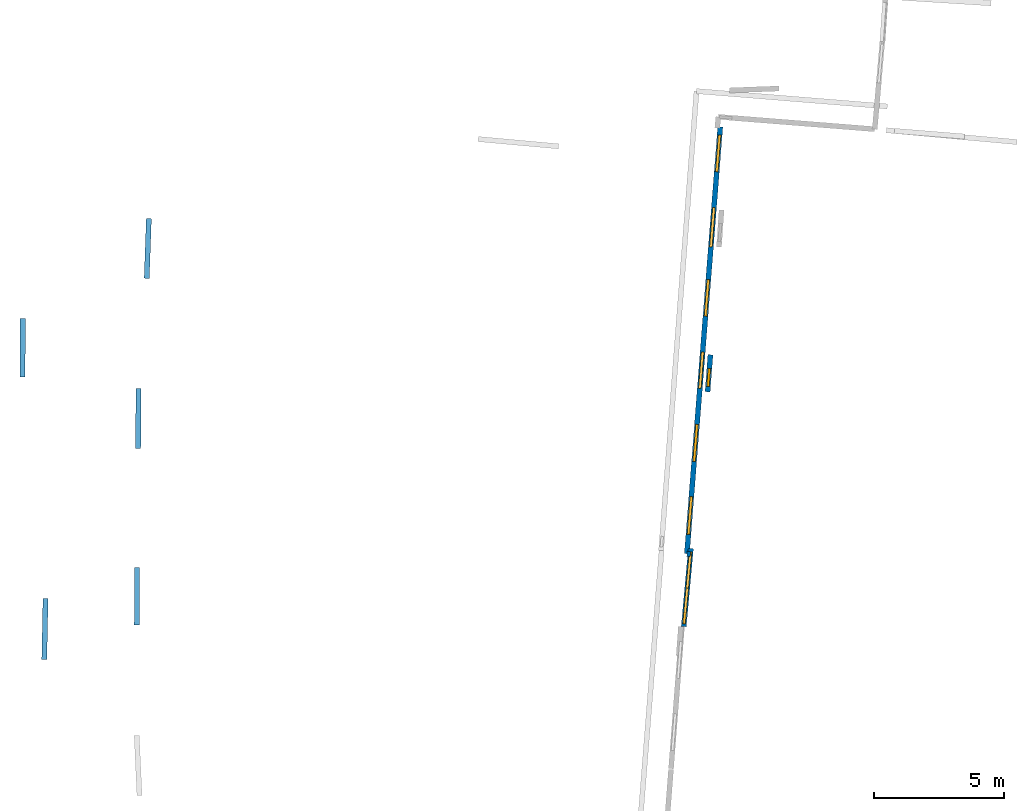
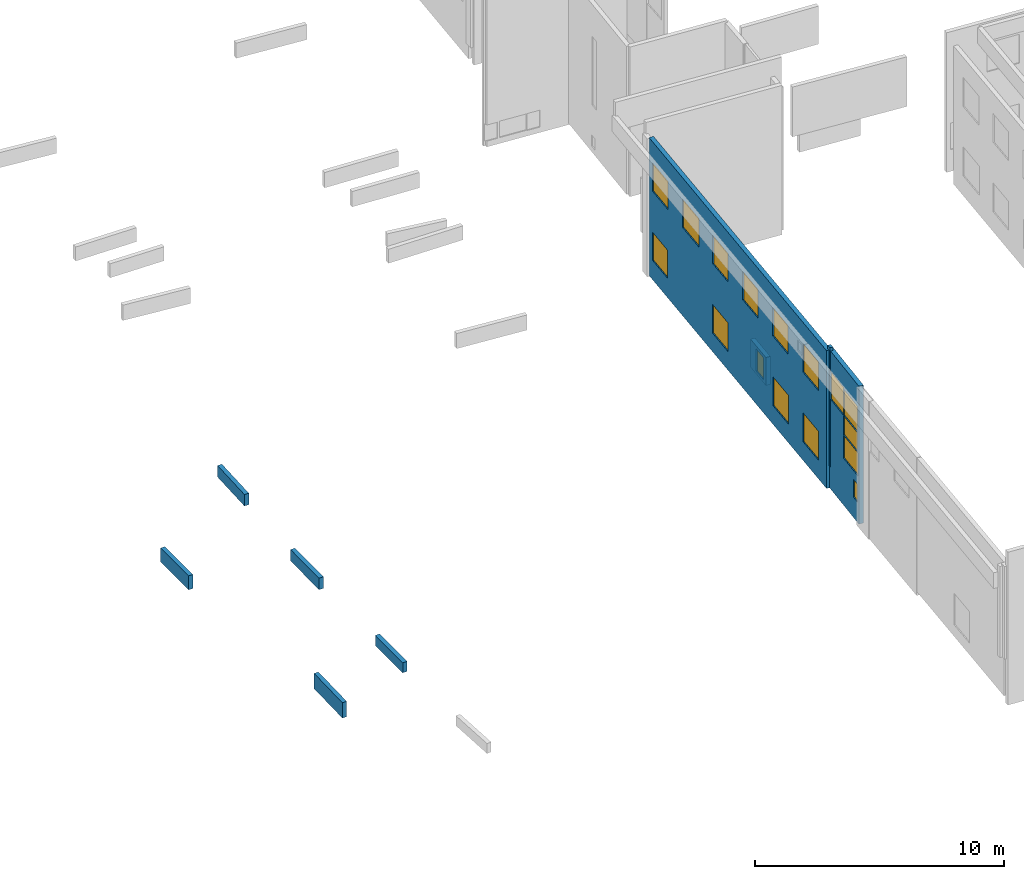
# One storey, part 5 of 27: 16 windows, 9 walls, 16 openings.
"""IFC2X3 building model written with IfcOpenShell, lengths in metres."""

from ifc_helpers import new_model, entity, si_unit, converted_unit, derived_unit, direction, frame, frame_2d, origin, origin_2d_with_axis, place, context, subcontext, project, spatial, polyline, rectangle, outline, extrude, source, transform, mapped, material, layer, layer_set, layer_usage, type_object, type_shapes, element, fill, save


model = new_model("IFC2X3")

# Units and contexts
model_context = context("Model", 3, precision=1e-05, world=origin(), true_north=direction((0.0, 1.0)))
body_context = subcontext(model_context, "Body", "Model", "MODEL_VIEW")
ifc_project = project(units=[si_unit("LENGTHUNIT", "METRE"), si_unit("AREAUNIT", "SQUARE_METRE"), si_unit("VOLUMEUNIT", "CUBIC_METRE"), converted_unit("PLANEANGLEUNIT", "DEGREE", entity("IfcRatioMeasure", 0.0174532925199433), si_unit("PLANEANGLEUNIT", "RADIAN"), dimensions=[0, 0, 0, 0, 0, 0, 0]), si_unit("MASSUNIT", "GRAM", prefix="KILO"), derived_unit("MASSDENSITYUNIT", [(si_unit("MASSUNIT", "GRAM", prefix="KILO"), 1), (si_unit("LENGTHUNIT", "METRE"), -3)]), derived_unit("MOMENTOFINERTIAUNIT", [(si_unit("LENGTHUNIT", "METRE"), 4)]), si_unit("TIMEUNIT", "SECOND"), si_unit("FREQUENCYUNIT", "HERTZ"), si_unit("THERMODYNAMICTEMPERATUREUNIT", "DEGREE_CELSIUS"), derived_unit("THERMALTRANSMITTANCEUNIT", [(si_unit("MASSUNIT", "GRAM", prefix="KILO"), 1), (si_unit("THERMODYNAMICTEMPERATUREUNIT", "KELVIN"), -1), (si_unit("TIMEUNIT", "SECOND"), -3)]), derived_unit("VOLUMETRICFLOWRATEUNIT", [(si_unit("LENGTHUNIT", "METRE"), 3), (si_unit("TIMEUNIT", "SECOND"), -1)]), si_unit("ELECTRICCURRENTUNIT", "AMPERE"), si_unit("ELECTRICVOLTAGEUNIT", "VOLT"), si_unit("POWERUNIT", "WATT"), si_unit("FORCEUNIT", "NEWTON", prefix="KILO"), si_unit("ILLUMINANCEUNIT", "LUX"), si_unit("LUMINOUSFLUXUNIT", "LUMEN"), si_unit("LUMINOUSINTENSITYUNIT", "CANDELA"), derived_unit("USERDEFINED", [(si_unit("MASSUNIT", "GRAM", prefix="KILO"), -1), (si_unit("LENGTHUNIT", "METRE"), -2), (si_unit("TIMEUNIT", "SECOND"), 3), (si_unit("LUMINOUSFLUXUNIT", "LUMEN"), 1)]), derived_unit("LINEARVELOCITYUNIT", [(si_unit("LENGTHUNIT", "METRE"), 1), (si_unit("TIMEUNIT", "SECOND"), -1)]), si_unit("PRESSUREUNIT", "PASCAL"), derived_unit("USERDEFINED", [(si_unit("LENGTHUNIT", "METRE"), -2), (si_unit("MASSUNIT", "GRAM", prefix="KILO"), 1), (si_unit("TIMEUNIT", "SECOND"), -2)]), derived_unit("LINEARFORCEUNIT", [(si_unit("MASSUNIT", "GRAM", prefix="KILO"), 1), (si_unit("LENGTHUNIT", "METRE"), 1), (si_unit("TIMEUNIT", "SECOND"), -2), (si_unit("LENGTHUNIT", "METRE"), -1)]), derived_unit("PLANARFORCEUNIT", [(si_unit("MASSUNIT", "GRAM", prefix="KILO"), 1), (si_unit("LENGTHUNIT", "METRE"), 1), (si_unit("TIMEUNIT", "SECOND"), -2), (si_unit("LENGTHUNIT", "METRE"), -2)])], contexts=[model_context])

# Site, building, storey
placement_1 = place(None, origin())
site = spatial("IfcSite", under=ifc_project, at=placement_1, CompositionType="ELEMENT")
building = spatial("IfcBuilding", under=site, at=placement_1, CompositionType="ELEMENT")
storey_placement = place(placement_1, frame((0.0, 0.0, -61.043098449707)))
storey = spatial("IfcBuildingStorey", under=building, at=storey_placement, Name="level_-61.043098", CompositionType="ELEMENT", Elevation=-61.043098449707)

# Wall, openings, windows
ifc_material_1 = material(Name="Default wall")
ifc_layer = layer(ifc_material_1, 0.2)
ifc_layer_set = layer_set([ifc_layer], Name="wall_thickness_0.2000")
ifc_layer_usage = layer_usage(ifc_layer_set, "AXIS2", "POSITIVE", -0.1)
wall_type = type_object("IfcWallType", Name="wall_thickness_0.2000", PredefinedType="STANDARD", material=ifc_layer_set)
placement_2 = place(placement_1, frame((0.0, 0.0, -60.9578857421875)))
wall_1_placement = place(placement_2, frame((-85.5225113799916, -13.7391285673502, 0.0), z_axis=(0.0, 0.0, 1.0), x_axis=(-0.0778817351425744, -0.996962604780732, 0.0)))
wall_1 = element("IfcWallStandardCase", 1, at=wall_1_placement, inside=storey, type_object=wall_type, material=ifc_layer_usage, Name="Wall:303", ObjectType="Wall", context=body_context, shape_type="SweptSolid", body=[
    extrude(outline(polyline([(16.513137194355, -0.1), (16.513137194355, 0.1), (0.0, 0.1), (0.0, -0.1), (16.513137194355, -0.1)])), origin(), (0.0, 0.0, 1.0), 6.74871063232422),
])
opening_1_placement = place(wall_1_placement, frame((0.320000121720632, -0.1, 4.32806777954102)))
opening_1 = element("IfcOpeningElement", 2, at=opening_1_placement, cuts=wall_1, Name="Opening : 1420 x 1390 : 23", ObjectType="Opening", context=body_context, shape_type="SweptSolid", body=[
    extrude(rectangle(XDim=1.42, YDim=1.39, at=frame_2d((0.695, 0.71), x_axis=(0.0, 1.0))), frame((0.0, 0.0, 0.0), z_axis=(0.0, 1.0, 0.0), x_axis=(0.0, 0.0, 1.0)), (0.0, 0.0, 1.0), 0.2),
])
opening_2_placement = place(wall_1_placement, frame((14.2999979344314, -0.1, 4.31306838989258)))
opening_2 = element("IfcOpeningElement", 3, at=opening_2_placement, cuts=wall_1, Name="Opening : 1450 x 1410 : 24", ObjectType="Opening", context=body_context, shape_type="SweptSolid", body=[
    extrude(rectangle(XDim=1.45, YDim=1.41, at=frame_2d((0.705, 0.725), x_axis=(0.0, 1.0))), frame((0.0, 0.0, 0.0), z_axis=(0.0, 1.0, 0.0), x_axis=(0.0, 0.0, 1.0)), (0.0, 0.0, 1.0), 0.2),
])
opening_3_placement = place(wall_1_placement, frame((3.12000031696189, -0.1, 4.31806564331055)))
opening_3 = element("IfcOpeningElement", 4, at=opening_3_placement, cuts=wall_1, Name="Opening : 1535 x 1395 : 25", ObjectType="Opening", context=body_context, shape_type="SweptSolid", body=[
    extrude(rectangle(XDim=1.535, YDim=1.395, at=frame_2d((0.6975, 0.7675), x_axis=(0.0, 1.0))), frame((0.0, 0.0, 0.0), z_axis=(0.0, 1.0, 0.0), x_axis=(0.0, 0.0, 1.0)), (0.0, 0.0, 1.0), 0.2),
])
opening_4_placement = place(wall_1_placement, frame((5.91499989962284, -0.1, 4.31806564331055)))
opening_4 = element("IfcOpeningElement", 5, at=opening_4_placement, cuts=wall_1, Name="Opening : 1410 x 1395 : 26", ObjectType="Opening", context=body_context, shape_type="SweptSolid", body=[
    extrude(rectangle(XDim=1.41, YDim=1.395, at=frame_2d((0.6975, 0.705), x_axis=(0.0, 1.0))), frame((0.0, 0.0, 0.0), z_axis=(0.0, 1.0, 0.0), x_axis=(0.0, 0.0, 1.0)), (0.0, 0.0, 1.0), 0.2),
])
opening_5_placement = place(wall_1_placement, frame((8.71500104564173, -0.1, 4.31306838989258)))
opening_5 = element("IfcOpeningElement", 6, at=opening_5_placement, cuts=wall_1, Name="Opening : 1400 x 1395 : 27", ObjectType="Opening", context=body_context, shape_type="SweptSolid", body=[
    extrude(rectangle(XDim=1.4, YDim=1.395, at=frame_2d((0.6975, 0.7), x_axis=(0.0, 1.0))), frame((0.0, 0.0, 0.0), z_axis=(0.0, 1.0, 0.0), x_axis=(0.0, 0.0, 1.0)), (0.0, 0.0, 1.0), 0.2),
])
opening_6_placement = place(wall_1_placement, frame((11.5050002533257, -0.1, 4.31306838989258)))
opening_6 = element("IfcOpeningElement", 7, at=opening_6_placement, cuts=wall_1, Name="Opening : 1440 x 1400 : 28", ObjectType="Opening", context=body_context, shape_type="SweptSolid", body=[
    extrude(rectangle(XDim=1.44, YDim=1.4, at=frame_2d((0.7, 0.72), x_axis=(0.0, 1.0))), frame((0.0, 0.0, 0.0), z_axis=(0.0, 1.0, 0.0), x_axis=(0.0, 0.0, 1.0)), (0.0, 0.0, 1.0), 0.2),
])
opening_7_placement = place(wall_1_placement, frame((0.315000103330809, -0.1, 0.943065643310547)))
opening_7 = element("IfcOpeningElement", 8, at=opening_7_placement, cuts=wall_1, Name="Opening : 1420 x 1375 : 29", ObjectType="Opening", context=body_context, shape_type="SweptSolid", body=[
    extrude(rectangle(XDim=1.42, YDim=1.375, at=frame_2d((0.6875, 0.71), x_axis=(0.0, 1.0))), frame((0.0, 0.0, 0.0), z_axis=(0.0, 1.0, 0.0), x_axis=(0.0, 0.0, 1.0)), (0.0, 0.0, 1.0), 0.2),
])
opening_8_placement = place(wall_1_placement, frame((11.5150002901054, -0.1, 0.908065795898438)))
opening_8 = element("IfcOpeningElement", 9, at=opening_8_placement, cuts=wall_1, Name="Opening : 1435 x 1410 : 30", ObjectType="Opening", context=body_context, shape_type="SweptSolid", body=[
    extrude(rectangle(XDim=1.435, YDim=1.41, at=frame_2d((0.705, 0.7175), x_axis=(0.0, 1.0))), frame((0.0, 0.0, 0.0), z_axis=(0.0, 1.0, 0.0), x_axis=(0.0, 0.0, 1.0)), (0.0, 0.0, 1.0), 0.2),
])
opening_9_placement = place(wall_1_placement, frame((14.3099998727663, -0.1, 0.908065795898438)))
opening_9 = element("IfcOpeningElement", 10, at=opening_9_placement, cuts=wall_1, Name="Opening : 1455 x 1415 : 31", ObjectType="Opening", context=body_context, shape_type="SweptSolid", body=[
    extrude(rectangle(XDim=1.455, YDim=1.415, at=frame_2d((0.7075, 0.7275), x_axis=(0.0, 1.0))), frame((0.0, 0.0, 0.0), z_axis=(0.0, 1.0, 0.0), x_axis=(0.0, 0.0, 1.0)), (0.0, 0.0, 1.0), 0.2),
])
opening_10_placement = place(wall_1_placement, frame((5.91000083201065, -0.1, 0.908065795898438)))
opening_10 = element("IfcOpeningElement", 11, at=opening_10_placement, cuts=wall_1, Name="Opening : 1415 x 1405 : 32", ObjectType="Opening", context=body_context, shape_type="SweptSolid", body=[
    extrude(rectangle(XDim=1.415, YDim=1.405, at=frame_2d((0.7025, 0.7075), x_axis=(0.0, 1.0))), frame((0.0, 0.0, 0.0), z_axis=(0.0, 1.0, 0.0), x_axis=(0.0, 0.0, 1.0)), (0.0, 0.0, 1.0), 0.2),
])
ifc_material_2 = material(Name="Window Default")
window_style_1 = type_object("IfcWindowStyle", Name="Window : 1420 x 1390mm", ConstructionType="NOTDEFINED", OperationType="NOTDEFINED", ParameterTakesPrecedence=False, Sizeable=False, material=ifc_material_2)
shared_shape_1 = source(origin(), body_context, "Body", "SweptSolid", [
    extrude(rectangle(XDim=0.1, YDim=1.42, at=origin_2d_with_axis()), frame((0.71, 0.1, 0.0), z_axis=(0.0, 0.0, 1.0), x_axis=(0.0, 1.0, 0.0)), (0.0, 0.0, 1.0), 1.39),
])
type_shapes(window_style_1, [shared_shape_1])
window_1_placement = place(opening_1_placement, origin())
window_1 = element("IfcWindow", 12, at=window_1_placement, inside=storey, type_object=window_style_1, Name="Window : 1420 x 1390mm : 20", ObjectType="Window : 1420 x 1390mm", OverallHeight=1.39, OverallWidth=1.42, context=body_context, shape_type="MappedRepresentation", body=[
    mapped(shared_shape_1, transform((0.0, 0.0, 0.0), scale=1.0)),
])
fill(opening_1, window_1)
window_style_2 = type_object("IfcWindowStyle", Name="Window : 1415 x 1405mm", ConstructionType="NOTDEFINED", OperationType="NOTDEFINED", ParameterTakesPrecedence=False, Sizeable=False, material=ifc_material_2)
shared_shape_2 = source(origin(), body_context, "Body", "SweptSolid", [
    extrude(rectangle(XDim=0.1, YDim=1.415, at=origin_2d_with_axis()), frame((0.7075, 0.1, 0.0), z_axis=(0.0, 0.0, 1.0), x_axis=(0.0, 1.0, 0.0)), (0.0, 0.0, 1.0), 1.405),
])
type_shapes(window_style_2, [shared_shape_2])
window_2_placement = place(opening_10_placement, origin())
window_2 = element("IfcWindow", 13, at=window_2_placement, inside=storey, type_object=window_style_2, Name="Window : 1415 x 1405mm : 29", ObjectType="Window : 1415 x 1405mm", OverallHeight=1.405, OverallWidth=1.415, context=body_context, shape_type="MappedRepresentation", body=[
    mapped(shared_shape_2, transform((0.0, 0.0, 0.0), scale=1.0)),
])
fill(opening_10, window_2)
window_style_3 = type_object("IfcWindowStyle", Name="Window : 1450 x 1410mm", ConstructionType="NOTDEFINED", OperationType="NOTDEFINED", ParameterTakesPrecedence=False, Sizeable=False, material=ifc_material_2)
shared_shape_3 = source(origin(), body_context, "Body", "SweptSolid", [
    extrude(rectangle(XDim=0.1, YDim=1.45, at=origin_2d_with_axis()), frame((0.725, 0.1, 0.0), z_axis=(0.0, 0.0, 1.0), x_axis=(0.0, 1.0, 0.0)), (0.0, 0.0, 1.0), 1.41),
])
type_shapes(window_style_3, [shared_shape_3])
window_3_placement = place(opening_2_placement, origin())
window_3 = element("IfcWindow", 14, at=window_3_placement, inside=storey, type_object=window_style_3, Name="Window : 1450 x 1410mm : 21", ObjectType="Window : 1450 x 1410mm", OverallHeight=1.41, OverallWidth=1.45, context=body_context, shape_type="MappedRepresentation", body=[
    mapped(shared_shape_3, transform((0.0, 0.0, 0.0), scale=1.0)),
])
fill(opening_2, window_3)
window_style_4 = type_object("IfcWindowStyle", Name="Window : 1535 x 1395mm", ConstructionType="NOTDEFINED", OperationType="NOTDEFINED", ParameterTakesPrecedence=False, Sizeable=False, material=ifc_material_2)
shared_shape_4 = source(origin(), body_context, "Body", "SweptSolid", [
    extrude(rectangle(XDim=0.1, YDim=1.535, at=origin_2d_with_axis()), frame((0.7675, 0.1, 0.0), z_axis=(0.0, 0.0, 1.0), x_axis=(0.0, 1.0, 0.0)), (0.0, 0.0, 1.0), 1.395),
])
type_shapes(window_style_4, [shared_shape_4])
window_4_placement = place(opening_3_placement, origin())
window_4 = element("IfcWindow", 15, at=window_4_placement, inside=storey, type_object=window_style_4, Name="Window : 1535 x 1395mm : 22", ObjectType="Window : 1535 x 1395mm", OverallHeight=1.395, OverallWidth=1.535, context=body_context, shape_type="MappedRepresentation", body=[
    mapped(shared_shape_4, transform((0.0, 0.0, 0.0), scale=1.0)),
])
fill(opening_3, window_4)
window_style_5 = type_object("IfcWindowStyle", Name="Window : 1410 x 1395mm", ConstructionType="NOTDEFINED", OperationType="NOTDEFINED", ParameterTakesPrecedence=False, Sizeable=False, material=ifc_material_2)
shared_shape_5 = source(origin(), body_context, "Body", "SweptSolid", [
    extrude(rectangle(XDim=0.1, YDim=1.41, at=origin_2d_with_axis()), frame((0.705, 0.1, 0.0), z_axis=(0.0, 0.0, 1.0), x_axis=(0.0, 1.0, 0.0)), (0.0, 0.0, 1.0), 1.395),
])
type_shapes(window_style_5, [shared_shape_5])
window_5_placement = place(opening_4_placement, origin())
window_5 = element("IfcWindow", 16, at=window_5_placement, inside=storey, type_object=window_style_5, Name="Window : 1410 x 1395mm : 23", ObjectType="Window : 1410 x 1395mm", OverallHeight=1.395, OverallWidth=1.41, context=body_context, shape_type="MappedRepresentation", body=[
    mapped(shared_shape_5, transform((0.0, 0.0, 0.0), scale=1.0)),
])
fill(opening_4, window_5)
window_style_6 = type_object("IfcWindowStyle", Name="Window : 1400 x 1395mm", ConstructionType="NOTDEFINED", OperationType="NOTDEFINED", ParameterTakesPrecedence=False, Sizeable=False, material=ifc_material_2)
shared_shape_6 = source(origin(), body_context, "Body", "SweptSolid", [
    extrude(rectangle(XDim=0.1, YDim=1.4, at=origin_2d_with_axis()), frame((0.7, 0.1, 0.0), z_axis=(0.0, 0.0, 1.0), x_axis=(0.0, 1.0, 0.0)), (0.0, 0.0, 1.0), 1.395),
])
type_shapes(window_style_6, [shared_shape_6])
window_6_placement = place(opening_5_placement, origin())
window_6 = element("IfcWindow", 17, at=window_6_placement, inside=storey, type_object=window_style_6, Name="Window : 1400 x 1395mm : 24", ObjectType="Window : 1400 x 1395mm", OverallHeight=1.395, OverallWidth=1.4, context=body_context, shape_type="MappedRepresentation", body=[
    mapped(shared_shape_6, transform((0.0, 0.0, 0.0), scale=1.0)),
])
fill(opening_5, window_6)
window_style_7 = type_object("IfcWindowStyle", Name="Window : 1440 x 1400mm", ConstructionType="NOTDEFINED", OperationType="NOTDEFINED", ParameterTakesPrecedence=False, Sizeable=False, material=ifc_material_2)
shared_shape_7 = source(origin(), body_context, "Body", "SweptSolid", [
    extrude(rectangle(XDim=0.1, YDim=1.44, at=origin_2d_with_axis()), frame((0.72, 0.1, 0.0), z_axis=(0.0, 0.0, 1.0), x_axis=(0.0, 1.0, 0.0)), (0.0, 0.0, 1.0), 1.4),
])
type_shapes(window_style_7, [shared_shape_7])
window_7_placement = place(opening_6_placement, origin())
window_7 = element("IfcWindow", 18, at=window_7_placement, inside=storey, type_object=window_style_7, Name="Window : 1440 x 1400mm : 25", ObjectType="Window : 1440 x 1400mm", OverallHeight=1.4, OverallWidth=1.44, context=body_context, shape_type="MappedRepresentation", body=[
    mapped(shared_shape_7, transform((0.0, 0.0, 0.0), scale=1.0)),
])
fill(opening_6, window_7)
window_style_8 = type_object("IfcWindowStyle", Name="Window : 1420 x 1375mm", ConstructionType="NOTDEFINED", OperationType="NOTDEFINED", ParameterTakesPrecedence=False, Sizeable=False, material=ifc_material_2)
shared_shape_8 = source(origin(), body_context, "Body", "SweptSolid", [
    extrude(rectangle(XDim=0.1, YDim=1.42, at=origin_2d_with_axis()), frame((0.71, 0.1, 0.0), z_axis=(0.0, 0.0, 1.0), x_axis=(0.0, 1.0, 0.0)), (0.0, 0.0, 1.0), 1.375),
])
type_shapes(window_style_8, [shared_shape_8])
window_8_placement = place(opening_7_placement, origin())
window_8 = element("IfcWindow", 19, at=window_8_placement, inside=storey, type_object=window_style_8, Name="Window : 1420 x 1375mm : 26", ObjectType="Window : 1420 x 1375mm", OverallHeight=1.375, OverallWidth=1.42, context=body_context, shape_type="MappedRepresentation", body=[
    mapped(shared_shape_8, transform((0.0, 0.0, 0.0), scale=1.0)),
])
fill(opening_7, window_8)
window_style_9 = type_object("IfcWindowStyle", Name="Window : 1435 x 1410mm", ConstructionType="NOTDEFINED", OperationType="NOTDEFINED", ParameterTakesPrecedence=False, Sizeable=False, material=ifc_material_2)
shared_shape_9 = source(origin(), body_context, "Body", "SweptSolid", [
    extrude(rectangle(XDim=0.1, YDim=1.435, at=origin_2d_with_axis()), frame((0.7175, 0.1, 0.0), z_axis=(0.0, 0.0, 1.0), x_axis=(0.0, 1.0, 0.0)), (0.0, 0.0, 1.0), 1.41),
])
type_shapes(window_style_9, [shared_shape_9])
window_9_placement = place(opening_8_placement, origin())
window_9 = element("IfcWindow", 20, at=window_9_placement, inside=storey, type_object=window_style_9, Name="Window : 1435 x 1410mm : 27", ObjectType="Window : 1435 x 1410mm", OverallHeight=1.41, OverallWidth=1.435, context=body_context, shape_type="MappedRepresentation", body=[
    mapped(shared_shape_9, transform((0.0, 0.0, 0.0), scale=1.0)),
])
fill(opening_8, window_9)
window_style_10 = type_object("IfcWindowStyle", Name="Window : 1455 x 1415mm", ConstructionType="NOTDEFINED", OperationType="NOTDEFINED", ParameterTakesPrecedence=False, Sizeable=False, material=ifc_material_2)
shared_shape_10 = source(origin(), body_context, "Body", "SweptSolid", [
    extrude(rectangle(XDim=0.1, YDim=1.455, at=origin_2d_with_axis()), frame((0.7275, 0.1, 0.0), z_axis=(0.0, 0.0, 1.0), x_axis=(0.0, 1.0, 0.0)), (0.0, 0.0, 1.0), 1.415),
])
type_shapes(window_style_10, [shared_shape_10])
window_10_placement = place(opening_9_placement, origin())
window_10 = element("IfcWindow", 21, at=window_10_placement, inside=storey, type_object=window_style_10, Name="Window : 1455 x 1415mm : 28", ObjectType="Window : 1455 x 1415mm", OverallHeight=1.415, OverallWidth=1.455, context=body_context, shape_type="MappedRepresentation", body=[
    mapped(shared_shape_10, transform((0.0, 0.0, 0.0), scale=1.0)),
])
fill(opening_9, window_10)

placement_3 = place(placement_1, frame((0.0, 0.0, -60.9578857421875)))
wall_2_placement = place(placement_3, frame((-86.6557621445655, -29.9994877663841, 0.0), z_axis=(0.0, 0.0, 1.0), x_axis=(-0.090893404097552, -0.995860627342782, 0.0)))
wall_2 = element("IfcWallStandardCase", 22, at=wall_2_placement, inside=storey, type_object=wall_type, material=ifc_layer_usage, Name="Wall:668", ObjectType="Wall", context=body_context, shape_type="SweptSolid", body=[
    extrude(outline(polyline([(3.02150984076525, -0.1), (3.02150984076525, 0.1), (0.0, 0.1), (0.0, -0.1), (3.02150984076525, -0.1)])), origin(), (0.0, 0.0, 1.0), 6.74871063232422),
])
opening_11_placement = place(wall_2_placement, frame((1.53620150487208, -0.1, 4.39424514770508)))
opening_11 = element("IfcOpeningElement", 23, at=opening_11_placement, cuts=wall_2, Name="Opening : 1355 x 1295 : 65", ObjectType="Opening", context=body_context, shape_type="SweptSolid", body=[
    extrude(rectangle(XDim=1.355, YDim=1.295, at=frame_2d((0.6475, 0.6775), x_axis=(0.0, 1.0))), frame((0.0, 0.0, 0.0), z_axis=(0.0, 1.0, 0.0), x_axis=(0.0, 0.0, 1.0)), (0.0, 0.0, 1.0), 0.2),
])
opening_12_placement = place(wall_2_placement, frame((1.53620150487208, -0.1, 3.43424224853516)))
opening_12 = element("IfcOpeningElement", 24, at=opening_12_placement, cuts=wall_2, Name="Opening : 1375 x 950 : 66", ObjectType="Opening", context=body_context, shape_type="SweptSolid", body=[
    extrude(rectangle(XDim=1.375, YDim=0.95, at=frame_2d((0.475, 0.6875), x_axis=(0.0, 1.0))), frame((0.0, 0.0, 0.0), z_axis=(0.0, 1.0, 0.0), x_axis=(0.0, 0.0, 1.0)), (0.0, 0.0, 1.0), 0.2),
])
opening_13_placement = place(wall_2_placement, frame((1.53620150487208, -0.1, 2.29924392700195)))
opening_13 = element("IfcOpeningElement", 25, at=opening_13_placement, cuts=wall_2, Name="Opening : 1385 x 1125 : 67", ObjectType="Opening", context=body_context, shape_type="SweptSolid", body=[
    extrude(rectangle(XDim=1.385, YDim=1.125, at=frame_2d((0.5625, 0.6925), x_axis=(0.0, 1.0))), frame((0.0, 0.0, 0.0), z_axis=(0.0, 1.0, 0.0), x_axis=(0.0, 0.0, 1.0)), (0.0, 0.0, 1.0), 0.2),
])
opening_14_placement = place(wall_2_placement, frame((2.48120260546089, -0.1, 0.989242553710938)))
opening_14 = element("IfcOpeningElement", 26, at=opening_14_placement, cuts=wall_2, Name="Opening : 410 x 875 : 68", ObjectType="Opening", context=body_context, shape_type="SweptSolid", body=[
    extrude(rectangle(XDim=0.41, YDim=0.875, at=frame_2d((0.4375, 0.205), x_axis=(0.0, 1.0))), frame((0.0, 0.0, 0.0), z_axis=(0.0, 1.0, 0.0), x_axis=(0.0, 0.0, 1.0)), (0.0, 0.0, 1.0), 0.2),
])
opening_15_placement = place(wall_2_placement, frame((0.126605393609432, -0.1, 4.3919792175293)))
opening_15 = element("IfcOpeningElement", 27, at=opening_15_placement, cuts=wall_2, Name="Opening : 1400 x 1360 : 69", ObjectType="Opening", context=body_context, shape_type="SweptSolid", body=[
    extrude(rectangle(XDim=1.4, YDim=1.36, at=frame_2d((0.68, 0.7), x_axis=(0.0, 1.0))), frame((0.0, 0.0, 0.0), z_axis=(0.0, 1.0, 0.0), x_axis=(0.0, 0.0, 1.0)), (0.0, 0.0, 1.0), 0.2),
])
window_style_11 = type_object("IfcWindowStyle", Name="Window : 1355 x 1295mm", ConstructionType="NOTDEFINED", OperationType="NOTDEFINED", ParameterTakesPrecedence=False, Sizeable=False, material=ifc_material_2)
shared_shape_11 = source(origin(), body_context, "Body", "SweptSolid", [
    extrude(rectangle(XDim=0.1, YDim=1.355, at=origin_2d_with_axis()), frame((0.6775, 0.1, 0.0), z_axis=(0.0, 0.0, 1.0), x_axis=(0.0, 1.0, 0.0)), (0.0, 0.0, 1.0), 1.295),
])
type_shapes(window_style_11, [shared_shape_11])
window_11_placement = place(opening_11_placement, origin())
window_11 = element("IfcWindow", 28, at=window_11_placement, inside=storey, type_object=window_style_11, Name="Window : 1355 x 1295mm : 57", ObjectType="Window : 1355 x 1295mm", OverallHeight=1.295, OverallWidth=1.355, context=body_context, shape_type="MappedRepresentation", body=[
    mapped(shared_shape_11, transform((0.0, 0.0, 0.0), scale=1.0)),
])
fill(opening_11, window_11)
window_style_12 = type_object("IfcWindowStyle", Name="Window : 1375 x 950mm", ConstructionType="NOTDEFINED", OperationType="NOTDEFINED", ParameterTakesPrecedence=False, Sizeable=False, material=ifc_material_2)
shared_shape_12 = source(origin(), body_context, "Body", "SweptSolid", [
    extrude(rectangle(XDim=0.1, YDim=1.375, at=origin_2d_with_axis()), frame((0.6875, 0.1, 0.0), z_axis=(0.0, 0.0, 1.0), x_axis=(0.0, 1.0, 0.0)), (0.0, 0.0, 1.0), 0.95),
])
type_shapes(window_style_12, [shared_shape_12])
window_12_placement = place(opening_12_placement, origin())
window_12 = element("IfcWindow", 29, at=window_12_placement, inside=storey, type_object=window_style_12, Name="Window : 1375 x 950mm : 58", ObjectType="Window : 1375 x 950mm", OverallHeight=0.95, OverallWidth=1.375, context=body_context, shape_type="MappedRepresentation", body=[
    mapped(shared_shape_12, transform((0.0, 0.0, 0.0), scale=1.0)),
])
fill(opening_12, window_12)
window_style_13 = type_object("IfcWindowStyle", Name="Window : 1385 x 1125mm", ConstructionType="NOTDEFINED", OperationType="NOTDEFINED", ParameterTakesPrecedence=False, Sizeable=False, material=ifc_material_2)
shared_shape_13 = source(origin(), body_context, "Body", "SweptSolid", [
    extrude(rectangle(XDim=0.1, YDim=1.385, at=origin_2d_with_axis()), frame((0.6925, 0.1, 0.0), z_axis=(0.0, 0.0, 1.0), x_axis=(0.0, 1.0, 0.0)), (0.0, 0.0, 1.0), 1.125),
])
type_shapes(window_style_13, [shared_shape_13])
window_13_placement = place(opening_13_placement, origin())
window_13 = element("IfcWindow", 30, at=window_13_placement, inside=storey, type_object=window_style_13, Name="Window : 1385 x 1125mm : 59", ObjectType="Window : 1385 x 1125mm", OverallHeight=1.125, OverallWidth=1.385, context=body_context, shape_type="MappedRepresentation", body=[
    mapped(shared_shape_13, transform((0.0, 0.0, 0.0), scale=1.0)),
])
fill(opening_13, window_13)
window_style_14 = type_object("IfcWindowStyle", Name="Window : 410 x 875mm", ConstructionType="NOTDEFINED", OperationType="NOTDEFINED", ParameterTakesPrecedence=False, Sizeable=False, material=ifc_material_2)
shared_shape_14 = source(origin(), body_context, "Body", "SweptSolid", [
    extrude(rectangle(XDim=0.1, YDim=0.41, at=origin_2d_with_axis()), frame((0.205, 0.1, 0.0), z_axis=(0.0, 0.0, 1.0), x_axis=(0.0, 1.0, 0.0)), (0.0, 0.0, 1.0), 0.875),
])
type_shapes(window_style_14, [shared_shape_14])
window_14_placement = place(opening_14_placement, origin())
window_14 = element("IfcWindow", 31, at=window_14_placement, inside=storey, type_object=window_style_14, Name="Window : 410 x 875mm : 60", ObjectType="Window : 410 x 875mm", OverallHeight=0.875, OverallWidth=0.41, context=body_context, shape_type="MappedRepresentation", body=[
    mapped(shared_shape_14, transform((0.0, 0.0, 0.0), scale=1.0)),
])
fill(opening_14, window_14)
window_style_15 = type_object("IfcWindowStyle", Name="Window : 1400 x 1360mm", ConstructionType="NOTDEFINED", OperationType="NOTDEFINED", ParameterTakesPrecedence=False, Sizeable=False, material=ifc_material_2)
shared_shape_15 = source(origin(), body_context, "Body", "SweptSolid", [
    extrude(rectangle(XDim=0.1, YDim=1.4, at=origin_2d_with_axis()), frame((0.7, 0.1, 0.0), z_axis=(0.0, 0.0, 1.0), x_axis=(0.0, 1.0, 0.0)), (0.0, 0.0, 1.0), 1.36),
])
type_shapes(window_style_15, [shared_shape_15])
window_15_placement = place(opening_15_placement, origin())
window_15 = element("IfcWindow", 32, at=window_15_placement, inside=storey, type_object=window_style_15, Name="Window : 1400 x 1360mm : 61", ObjectType="Window : 1400 x 1360mm", OverallHeight=1.36, OverallWidth=1.4, context=body_context, shape_type="MappedRepresentation", body=[
    mapped(shared_shape_15, transform((0.0, 0.0, 0.0), scale=1.0)),
])
fill(opening_15, window_15)

# Walls
placement_4 = place(placement_1, frame((0.0, 0.0, -60.8847198486328)))
wall_3_placement = place(placement_4, frame((-108.016679068064, -32.9399996938991, 0.0), z_axis=(0.0, 0.0, 1.0), x_axis=(0.00250892889840884, 0.999996852632938, 0.0)))
element("IfcWallStandardCase", 33, at=wall_3_placement, inside=storey, type_object=wall_type, material=ifc_layer_usage, Name="Wall:755", ObjectType="Wall", context=body_context, shape_type="SweptSolid", body=[
    extrude(outline(polyline([(2.21377306557889, -0.1), (2.21377306557889, 0.1), (0.0, 0.1), (0.0, -0.1), (2.21377306557889, -0.1)])), origin(), (0.0, 0.0, 1.0), 0.486675262451172),
])
placement_5 = place(placement_1, frame((0.0, 0.0, -60.9578857421875)))
wall_4_placement = place(placement_5, frame((-107.634459969617, -19.5811818228154, 0.0), z_axis=(0.0, 0.0, 1.0), x_axis=(0.0355028850473261, 0.999369573858098, 0.0)))
element("IfcWallStandardCase", 34, at=wall_4_placement, inside=storey, type_object=wall_type, material=ifc_layer_usage, Name="Wall:1294", ObjectType="Wall", context=body_context, shape_type="SweptSolid", body=[
    extrude(outline(polyline([(2.30088138294119, -0.1), (2.30088138294119, 0.1), (0.0, 0.1), (0.0, -0.1), (2.30088138294119, -0.1)])), origin(), (0.0, 0.0, 1.0), 0.559841156005859),
])

# Wall, opening, window
placement_6 = place(placement_1, frame((0.0, 0.0, -59.9867630004883)))
wall_5_placement = place(placement_6, frame((-85.9008490471808, -22.5273041760194, 0.0), z_axis=(0.0, 0.0, 1.0), x_axis=(-0.0773686453692825, -0.997002554015647, 0.0)))
wall_5 = element("IfcWallStandardCase", 35, at=wall_5_placement, inside=storey, type_object=wall_type, material=ifc_layer_usage, Name="Wall:1334", ObjectType="Wall", context=body_context, shape_type="SweptSolid", body=[
    extrude(outline(polyline([(1.43390161931092, -0.1), (1.43390161931092, 0.1), (0.0, 0.1), (0.0, -0.1), (1.43390161931092, -0.1)])), origin(), (0.0, 0.0, 1.0), 1.37465286254883),
])
opening_16_placement = place(wall_5_placement, frame((0.535001269385292, -0.1, 0.149681091308594)))
opening_16 = element("IfcOpeningElement", 36, at=opening_16_placement, cuts=wall_5, Name="Opening : 695 x 1080 : 201", ObjectType="Opening", context=body_context, shape_type="SweptSolid", body=[
    extrude(rectangle(XDim=0.695, YDim=1.08, at=frame_2d((0.54, 0.3475), x_axis=(0.0, 1.0))), frame((0.0, 0.0, 0.0), z_axis=(0.0, 1.0, 0.0), x_axis=(0.0, 0.0, 1.0)), (0.0, 0.0, 1.0), 0.2),
])
window_style_16 = type_object("IfcWindowStyle", Name="Window : 695 x 1080mm", ConstructionType="NOTDEFINED", OperationType="NOTDEFINED", ParameterTakesPrecedence=False, Sizeable=False, material=ifc_material_2)
shared_shape_16 = source(origin(), body_context, "Body", "SweptSolid", [
    extrude(rectangle(XDim=0.1, YDim=0.695, at=origin_2d_with_axis()), frame((0.3475, 0.1, 0.0), z_axis=(0.0, 0.0, 1.0), x_axis=(0.0, 1.0, 0.0)), (0.0, 0.0, 1.0), 1.08),
])
type_shapes(window_style_16, [shared_shape_16])
window_16_placement = place(opening_16_placement, origin())
window_16 = element("IfcWindow", 37, at=window_16_placement, inside=storey, type_object=window_style_16, Name="Window : 695 x 1080mm : 184", ObjectType="Window : 695 x 1080mm", OverallHeight=1.08, OverallWidth=0.695, context=body_context, shape_type="MappedRepresentation", body=[
    mapped(shared_shape_16, transform((0.0, 0.0, 0.0), scale=1.0)),
])
fill(opening_16, window_16)

# Walls
placement_7 = place(placement_1, frame((0.0, 0.0, -60.9578857421875)))
wall_6_placement = place(placement_7, frame((-107.966262695224, -26.1427612302063, 0.0), z_axis=(0.0, 0.0, 1.0), x_axis=(0.00573973456155389, 0.999983527587911, 0.0)))
element("IfcWallStandardCase", 38, at=wall_6_placement, inside=storey, type_object=wall_type, material=ifc_layer_usage, Name="Wall:1448", ObjectType="Wall", context=body_context, shape_type="SweptSolid", body=[
    extrude(outline(polyline([(2.30886257172031, -0.1), (2.30886257172031, 0.1), (0.0, 0.1), (0.0, -0.1), (2.30886257172031, -0.1)])), origin(), (0.0, 0.0, 1.0), 0.559841156005859),
])
placement_8 = place(placement_1, frame((0.0, 0.0, -59.8647689819336)))
wall_7_placement = place(placement_8, frame((-86.6751945628149, -30.2123669127118, 0.0), z_axis=(0.0, 0.0, 1.0), x_axis=(-0.997056330197357, 0.0766725140671669, 0.0)))
element("IfcWallStandardCase", 39, at=wall_7_placement, inside=storey, type_object=wall_type, material=ifc_layer_usage, Name="Wall:1554", ObjectType="Wall", context=body_context, shape_type="SweptSolid", body=[
    extrude(outline(polyline([(0.133786156252547, -0.1), (0.133786156252547, 0.1), (0.0, 0.1), (0.0, -0.1), (0.133786156252547, -0.1)])), origin(), (0.0, 0.0, 1.0), 5.83102416992188),
])
placement_9 = place(placement_1, frame((0.0, 0.0, -61.0783157348633)))
wall_8_placement = place(placement_9, frame((-112.415093617885, -21.1352084690656, 0.0), z_axis=(0.0, 0.0, 1.0), x_axis=(-0.00274319016955772, -0.999996237446768, 0.0)))
element("IfcWallStandardCase", 40, at=wall_8_placement, inside=storey, type_object=wall_type, material=ifc_layer_usage, Name="Wall:1669", ObjectType="Wall", context=body_context, shape_type="SweptSolid", body=[
    extrude(outline(polyline([(2.25000083635339, -0.1), (2.25000083635339, 0.1), (0.0, 0.1), (0.0, -0.1), (2.25000083635339, -0.1)])), origin(), (0.0, 0.0, 1.0), 0.680271148681641),
])
wall_9_placement = place(storey_placement, frame((-111.536624641922, -31.927988093498, 0.0), z_axis=(0.0, 0.0, 1.0), x_axis=(-0.020427293331946, -0.999791341074292, 0.0)))
element("IfcWallStandardCase", 41, at=wall_9_placement, inside=storey, type_object=wall_type, material=ifc_layer_usage, Name="Wall:1923", ObjectType="Wall", context=body_context, shape_type="SweptSolid", body=[
    extrude(outline(polyline([(2.35000054145949, -0.1), (2.35000054145949, 0.1), (0.0, 0.1), (0.0, -0.1), (2.35000054145949, -0.1)])), origin(), (0.0, 0.0, 1.0), 0.746963500976562),
])

save(model, "model.ifc")
